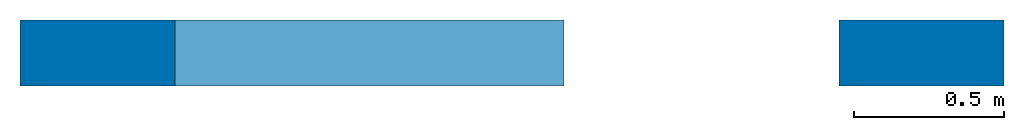
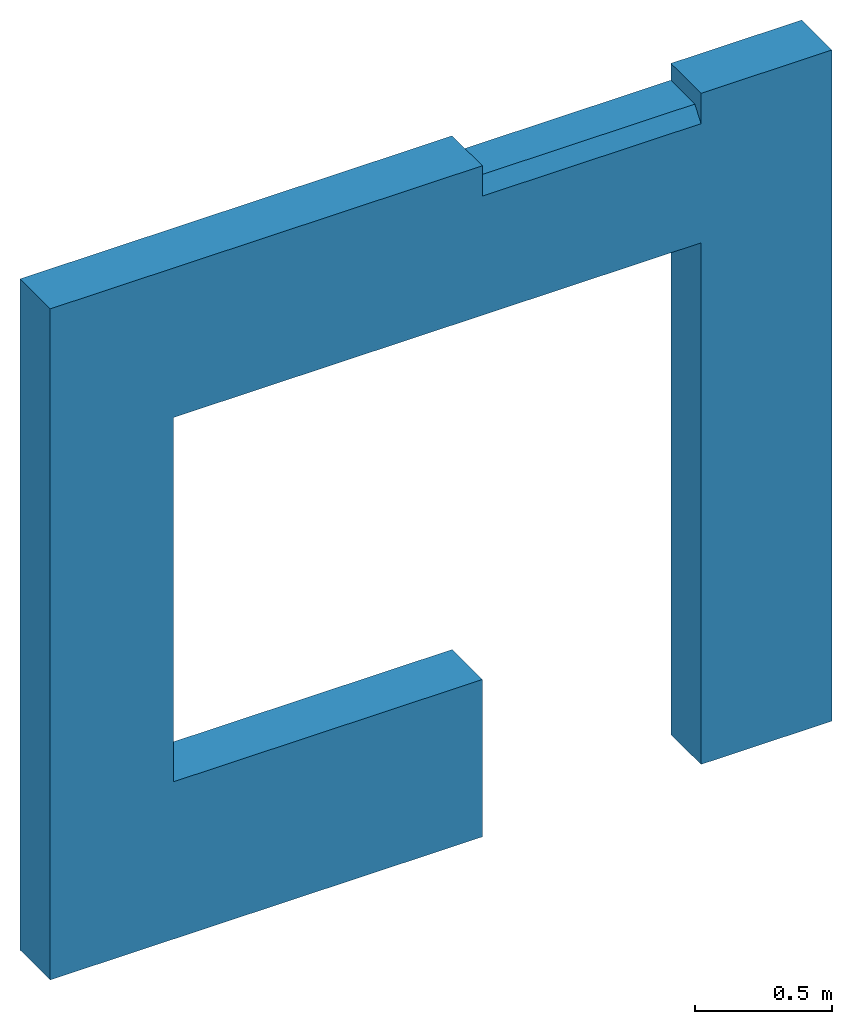
# One storey: 1 wall, 1 element without a shape of its own.
"""IFC2X3 building model written with IfcOpenShell, lengths in millimetres."""

from ifc_helpers import new_model, si_unit, frame, frame_2d, origin_with_axes, origin_2d_with_axis, place, context, subcontext, project, spatial, polyline, rectangle, outline, extrude, boolean, halfspace, material, type_object, element, aggregate, save


model = new_model("IFC2X3")

# Units and contexts
model_context = context("Model", 3, precision=1e-05, world=origin_with_axes())
body_context = subcontext(model_context, "Body", "Model", "MODEL_VIEW")
ifc_project = project(units=[si_unit("LENGTHUNIT", "METRE", prefix="MILLI"), si_unit("AREAUNIT", "SQUARE_METRE"), si_unit("VOLUMEUNIT", "CUBIC_METRE"), si_unit("MASSUNIT", "GRAM", prefix="KILO"), si_unit("TIMEUNIT", "SECOND"), si_unit("PLANEANGLEUNIT", "RADIAN"), si_unit("SOLIDANGLEUNIT", "STERADIAN"), si_unit("THERMODYNAMICTEMPERATUREUNIT", "DEGREE_CELSIUS"), si_unit("LUMINOUSINTENSITYUNIT", "LUMEN")], contexts=[model_context])

# Site, building, storey
site_placement = place(None, origin_with_axes())
site = spatial("IfcSite", under=ifc_project, at=site_placement, CompositionType="ELEMENT")
building_placement = place(site_placement, origin_with_axes())
building = spatial("IfcBuilding", under=site, at=building_placement, Name="C", CompositionType="ELEMENT")
storey_placement = place(building_placement, origin_with_axes())
storey = spatial("IfcBuildingStorey", under=building, at=storey_placement, Name="2", CompositionType="ELEMENT", Elevation=0.0)

# Assembly, wall
assembly_placement = place(storey_placement, origin_with_axes())
assembly = element("IfcElementAssembly", 1, at=assembly_placement, inside=storey, Name="Steel Assembly", AssemblyPlace="NOTDEFINED", PredefinedType="NOTDEFINED")
ifc_material = material(Name="COS5ggt")
wall_type = type_object("IfcWallType", Name="2985X220", PredefinedType="NOTDEFINED")
wall_placement = place(assembly_placement, frame((21549.9956394852, 14259.9957159644, 6.3664629124105e-12), z_axis=(0.0, 0.0, 1.0), x_axis=(1.0, 0.0, 0.0)))
solid_1 = boolean("DIFFERENCE", extrude(outline(polyline([(0.0, 0.0), (125.100700378953, -4.65661287307739e-10), (45.1638832094159, 3.19745373710975), (49.3605003357079, 108.113555908505), (1.99839007845912, 49.9600486757481), (0.0, 0.0)])), frame((2738.1222157683, -65.0000000380296, 0.0), z_axis=(0.0, 0.0, 1.0), x_axis=(0.0399678032275518, -0.999200968126615, 0.0)), (0.0, 0.0, 1.0), 2431.0), halfspace(frame((0.0, 0.0, -1160.5), z_axis=(-0.0282615037721814, -0.706541778485642, 0.70710678306666), x_axis=(0.0282615034435433, 0.70654178226202, 0.707106779306435)), False))
solid_2 = boolean("DIFFERENCE", boolean("DIFFERENCE", extrude(outline(polyline([(0.0, 0.0), (125.100700378953, -4.65661287307739e-10), (45.1638832094159, 3.19745373710975), (49.3605003357079, 108.113555908505), (1.99839007845912, 49.9600486757481), (0.0, 0.0)])), frame((2848.12221572324, -64.9999997750948, 2320.00000000203), z_axis=(-1.0, 0.0, 0.0), x_axis=(2.17345055886217e-10, -0.9992009681355, 0.0399678030054173)), (0.0, 0.0, 1.0), 2441.0), halfspace(frame((2.40488589042798e-07, -1.30239641293883e-09, -1110.50000000024), z_axis=(-0.0282615037721814, -0.706541778485642, 0.70710678306666), x_axis=(0.0282615034435433, 0.70654178226202, 0.707106779306435)), False)), halfspace(frame((2.40488589042798e-07, -1.30239641293883e-09, 1110.50000000024), z_axis=(0.0282615034435433, 0.70654178226202, 0.707106779306435), x_axis=(0.02826150344473, 0.706541782259596, -0.70710677930881)), True))
solid_3 = boolean("DIFFERENCE", boolean("DIFFERENCE", extrude(outline(polyline([(0.0, 0.0), (125.100700378953, -4.65661287307739e-10), (45.1638832094159, 3.19745373710975), (49.3605003357079, 108.113555908505), (1.99839007845912, 49.9600486757481), (0.0, 0.0)])), frame((518.122215767889, -65.0000000397213, 2430.0), z_axis=(0.0, 0.0, -1.0), x_axis=(-0.0399678037816825, -0.999200968104449, 0.0)), (0.0, 0.0, 1.0), 1841.0), halfspace(frame((0.0, 0.0, -810.5), z_axis=(-0.0282615037721814, -0.706541778485642, 0.70710678306666), x_axis=(0.0282615034435433, 0.70654178226202, 0.707106779306435)), False)), halfspace(frame((0.0, 0.0, 810.5), z_axis=(0.0282615034435433, 0.70654178226202, 0.707106779306435), x_axis=(0.02826150344473, 0.706541782259596, -0.70710677930881)), True))
solid_4 = boolean("DIFFERENCE", boolean("DIFFERENCE", extrude(outline(polyline([(0.0, 0.0), (125.100700378953, -4.65661287307739e-10), (45.1638832094159, 3.19745373710975), (49.3605003357079, 108.113555908505), (1.99839007845912, 49.9600486757481), (0.0, 0.0)])), frame((408.122215722895, -65.0000002072407, 700.000000091804), z_axis=(1.0, 0.0, 0.0), x_axis=(2.1735313946521e-10, -0.999200958736166, -0.0399680379894456)), (0.0, 0.0, 1.0), 1410.0), halfspace(frame((8.79299477674067e-08, 2.00217186829832e-07, -650.000000000149), z_axis=(0.0282615034435433, 0.70654178226202, 0.707106779306435), x_axis=(0.02826150344473, 0.706541782259596, -0.70710677930881)), False)), halfspace(frame((8.79299477674067e-08, 2.00217186829832e-07, 650.000000000149), z_axis=(0.0282615034435433, 0.70654178226202, 0.707106779306435), x_axis=(0.02826150344473, 0.706541782259596, -0.70710677930881)), True))
wall = element("IfcWall", 2, at=wall_placement, type_object=wall_type, material=ifc_material, ObjectType="2985X220", context=body_context, shape_type="CSG", body=[
    boolean("DIFFERENCE", boolean("DIFFERENCE", boolean("DIFFERENCE", boolean("DIFFERENCE", boolean("DIFFERENCE", boolean("DIFFERENCE", boolean("DIFFERENCE", extrude(rectangle(XDim=3288.99970000085, YDim=220.0, at=frame_2d((0.0, 1644.49985000042), x_axis=(0.0, -1.0))), frame((0.0, 0.0, 0.0), z_axis=(0.0, 0.0, 1.0), x_axis=(0.0, -1.0, 0.0)), (0.0, 0.0, 1.0), 2985.0), extrude(outline(polyline([(0.0, 0.0), (45.0000000702039, 0.0), (45.0000000702039, 110.0), (7.01929820934311e-08, 50.0), (0.0, 0.0)])), frame((1818.12570446939, -65.0000014755639, 2960.0), z_axis=(1.0, 0.0, 0.0), x_axis=(0.0, -1.0, 0.0)), (0.0, 0.0, 1.0), 920.0)), solid_1), solid_2), solid_3), solid_4), extrude(rectangle(XDim=220.0, YDim=75.0, at=origin_2d_with_axis()), frame((2738.12568908193, -8.01217425505887e-05, 2947.5), z_axis=(-1.0, 0.0, 0.0), x_axis=(0.0, -1.0, 0.0)), (0.0, 0.0, 1.0), 920.0)), extrude(outline(polyline([(0.0, 0.0), (2320.0, 0.0), (2320.0, 2220.00000000049), (700.0, 2220.00000000049), (700.0, 920.000000000207), (1.13558319106595e-16, 920.000000000207), (0.0, 0.0)])), frame((2738.12221572345, 184.999631980407, 1.90000950451883e-07), z_axis=(0.0, -1.0, 0.0), x_axis=(0.0, 0.0, 1.0)), (0.0, 0.0, 1.0), 380.0)),
])
aggregate(assembly, [wall])

save(model, "model.ifc")
